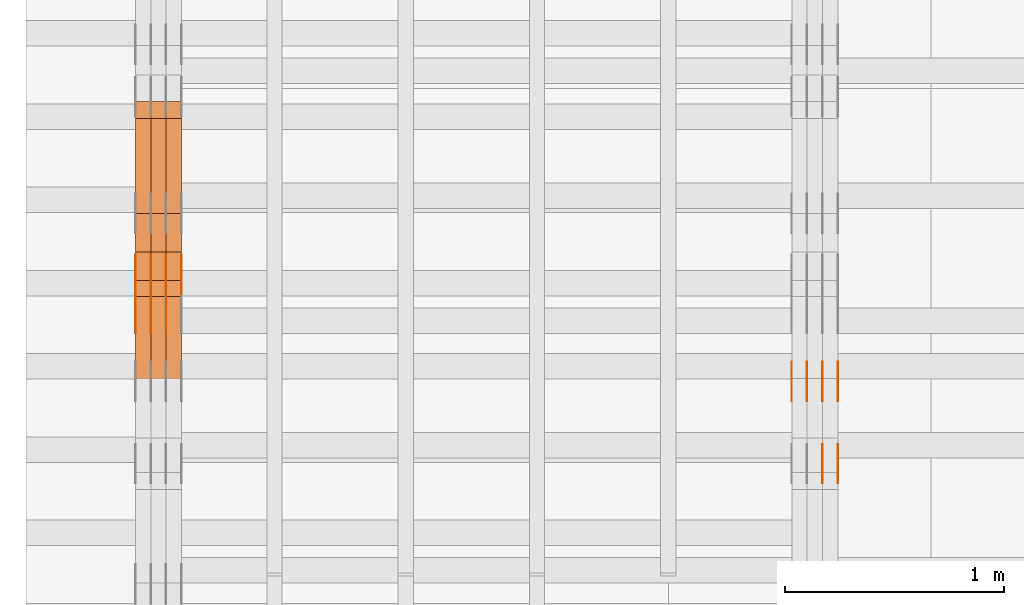
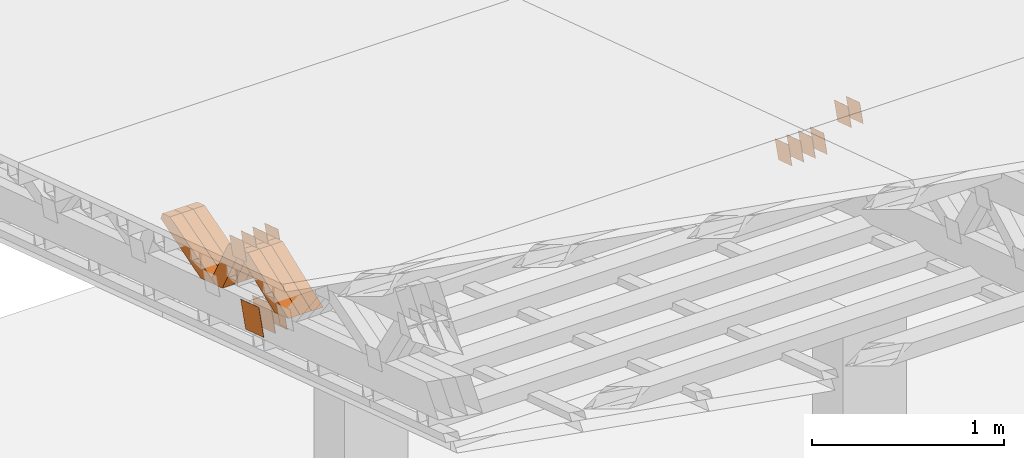
# One storey, part 175 of 385: 28 proxies.
"""IFC2X3 building model written with IfcOpenShell, lengths in millimetres."""

from ifc_helpers import new_model, entity, si_unit, converted_unit, derived_unit, direction, frame, origin, place, context, subcontext, project, spatial, polyline, outline, extrude, source, transform, mapped, material, type_object, type_shapes, element, save


model = new_model("IFC2X3")

# Units and contexts
model_context = context("Model", 3, precision=0.01, world=origin(), true_north=direction((6.12303176911189e-17, 1.0)))
body_context = subcontext(model_context, "Body", "Model", "MODEL_VIEW")
ifc_project = project(units=[si_unit("LENGTHUNIT", "METRE", prefix="MILLI"), si_unit("AREAUNIT", "SQUARE_METRE"), si_unit("VOLUMEUNIT", "CUBIC_METRE"), converted_unit("PLANEANGLEUNIT", "DEGREE", entity("IfcRatioMeasure", 0.0174532925199433), si_unit("PLANEANGLEUNIT", "RADIAN"), dimensions=[0, 0, 0, 0, 0, 0, 0]), si_unit("MASSUNIT", "GRAM", prefix="KILO"), derived_unit("MASSDENSITYUNIT", [(si_unit("MASSUNIT", "GRAM", prefix="KILO"), 1), (si_unit("LENGTHUNIT", "METRE"), -3)]), si_unit("TIMEUNIT", "SECOND"), si_unit("FREQUENCYUNIT", "HERTZ"), si_unit("THERMODYNAMICTEMPERATUREUNIT", "DEGREE_CELSIUS"), derived_unit("THERMALTRANSMITTANCEUNIT", [(si_unit("MASSUNIT", "GRAM", prefix="KILO"), 1), (si_unit("THERMODYNAMICTEMPERATUREUNIT", "KELVIN"), -1), (si_unit("TIMEUNIT", "SECOND"), -3)]), derived_unit("VOLUMETRICFLOWRATEUNIT", [(si_unit("LENGTHUNIT", "METRE"), 3), (si_unit("TIMEUNIT", "SECOND"), -1)]), si_unit("ELECTRICCURRENTUNIT", "AMPERE"), si_unit("ELECTRICVOLTAGEUNIT", "VOLT"), si_unit("POWERUNIT", "WATT"), si_unit("FORCEUNIT", "NEWTON", prefix="KILO"), si_unit("ILLUMINANCEUNIT", "LUX"), si_unit("LUMINOUSFLUXUNIT", "LUMEN"), si_unit("LUMINOUSINTENSITYUNIT", "CANDELA"), derived_unit("USERDEFINED", [(si_unit("MASSUNIT", "GRAM", prefix="KILO"), -1), (si_unit("LENGTHUNIT", "METRE"), -2), (si_unit("TIMEUNIT", "SECOND"), 3), (si_unit("LUMINOUSFLUXUNIT", "LUMEN"), 1)]), derived_unit("LINEARVELOCITYUNIT", [(si_unit("LENGTHUNIT", "METRE"), 1), (si_unit("TIMEUNIT", "SECOND"), -1)]), si_unit("PRESSUREUNIT", "PASCAL"), derived_unit("USERDEFINED", [(si_unit("LENGTHUNIT", "METRE"), -2), (si_unit("MASSUNIT", "GRAM", prefix="KILO"), 1), (si_unit("TIMEUNIT", "SECOND"), -2)])], contexts=[model_context])

# Site, building, storey
site_placement = place(None, origin())
site = spatial("IfcSite", under=ifc_project, at=site_placement, CompositionType="ELEMENT")
building_placement = place(site_placement, origin())
building = spatial("IfcBuilding", under=site, at=building_placement, CompositionType="ELEMENT")
storey_placement = place(building_placement, origin())
storey = spatial("IfcBuildingStorey", under=building, at=storey_placement, Name="Default", CompositionType="ELEMENT", Elevation=0.0)

# Proxies
ifc_material_1 = material(Name="IfcSurfaceStyle #65598")
building_element_proxy_type_1 = type_object("IfcBuildingElementProxyType", PredefinedType="NOTDEFINED", material=ifc_material_1)
shared_shape_1 = source(origin(), body_context, "Body", "SweptSolid", [
    extrude(outline(polyline([(-75.0001116115454, -60.0000599592451), (75.0000887592496, -60.0000599592451), (75.0001116115454, 60.0000599592451), (-75.0000887592496, 60.0000599592451), (-75.0001116115454, -60.0000599592451)])), frame((75.0001116115454, 60.0000599592451, 0.0), z_axis=(0.0, 0.0, 1.0), x_axis=(-1.0, 0.0, 0.0)), (0.0, 0.0, 1.0), 1.3),
])
type_shapes(building_element_proxy_type_1, [shared_shape_1])
proxy_1_placement = place(building_placement, frame((3386.29999999999, 21881.0815195707, 1532.2522473242), z_axis=(-1.0, 0.0, 0.0), x_axis=(0.0, -0.951056516295124, 0.309016994375039)))
element("IfcBuildingElementProxy", 1, at=proxy_1_placement, inside=storey, type_object=building_element_proxy_type_1, material=ifc_material_1, context=body_context, shape_type="MappedRepresentation", body=[
    mapped(shared_shape_1, transform((0.0, 0.0, 0.0), scale=1.0)),
])
ifc_material_2 = material(Name="IfcSurfaceStyle #65541")
building_element_proxy_type_2 = type_object("IfcBuildingElementProxyType", PredefinedType="NOTDEFINED", material=ifc_material_2)
shared_shape_2 = source(origin(), body_context, "Body", "SweptSolid", [
    extrude(outline(polyline([(-75.0001116115454, -60.0000599592451), (75.0000887592496, -60.0000599592451), (75.0001116115454, 60.0000599592451), (-75.0000887592496, 60.0000599592451), (-75.0001116115454, -60.0000599592451)])), frame((75.0001116115454, 60.0000599592451, 0.0), z_axis=(0.0, 0.0, 1.0), x_axis=(-1.0, 0.0, 0.0)), (0.0, 0.0, 1.0), 1.3),
])
type_shapes(building_element_proxy_type_2, [shared_shape_2])
proxy_2_placement = place(building_placement, frame((3315.0, 21881.0815195707, 1532.2522473242), z_axis=(-1.0, 0.0, 0.0), x_axis=(0.0, -0.951056516295124, 0.309016994375039)))
element("IfcBuildingElementProxy", 2, at=proxy_2_placement, inside=storey, type_object=building_element_proxy_type_2, material=ifc_material_2, context=body_context, shape_type="MappedRepresentation", body=[
    mapped(shared_shape_2, transform((0.0, 0.0, 0.0), scale=1.0)),
])
ifc_material_3 = material(Name="IfcSurfaceStyle #65484")
building_element_proxy_type_3 = type_object("IfcBuildingElementProxyType", PredefinedType="NOTDEFINED", material=ifc_material_3)
shared_shape_3 = source(origin(), body_context, "Body", "SweptSolid", [
    extrude(outline(polyline([(-75.0001116115454, -60.0000599592451), (75.0000887592496, -60.0000599592451), (75.0001116115454, 60.0000599592451), (-75.0000887592496, 60.0000599592451), (-75.0001116115454, -60.0000599592451)])), frame((75.0001116115454, 60.0000599592451, 0.0), z_axis=(0.0, 0.0, 1.0), x_axis=(-1.0, 0.0, 0.0)), (0.0, 0.0, 1.0), 1.3),
])
type_shapes(building_element_proxy_type_3, [shared_shape_3])
proxy_3_placement = place(building_placement, frame((3316.29999999999, 21881.0815195707, 1532.2522473242), z_axis=(-1.0, 0.0, 0.0), x_axis=(0.0, -0.951056516295124, 0.309016994375039)))
element("IfcBuildingElementProxy", 3, at=proxy_3_placement, inside=storey, type_object=building_element_proxy_type_3, material=ifc_material_3, context=body_context, shape_type="MappedRepresentation", body=[
    mapped(shared_shape_3, transform((0.0, 0.0, 0.0), scale=1.0)),
])
ifc_material_4 = material(Name="IfcSurfaceStyle #65427")
building_element_proxy_type_4 = type_object("IfcBuildingElementProxyType", PredefinedType="NOTDEFINED", material=ifc_material_4)
shared_shape_4 = source(origin(), body_context, "Body", "SweptSolid", [
    extrude(outline(polyline([(-75.0001116115454, -60.0000599592451), (75.0000887592496, -60.0000599592451), (75.0001116115454, 60.0000599592451), (-75.0000887592496, 60.0000599592451), (-75.0001116115454, -60.0000599592451)])), frame((75.0001116115454, 60.0000599592451, 0.0), z_axis=(0.0, 0.0, 1.0), x_axis=(-1.0, 0.0, 0.0)), (0.0, 0.0, 1.0), 1.29999999999999),
])
type_shapes(building_element_proxy_type_4, [shared_shape_4])
proxy_4_placement = place(building_placement, frame((3245.0, 21881.0815195707, 1532.2522473242), z_axis=(-1.0, 0.0, 0.0), x_axis=(0.0, -0.951056516295124, 0.309016994375039)))
element("IfcBuildingElementProxy", 4, at=proxy_4_placement, inside=storey, type_object=building_element_proxy_type_4, material=ifc_material_4, context=body_context, shape_type="MappedRepresentation", body=[
    mapped(shared_shape_4, transform((0.0, 0.0, 0.0), scale=1.0)),
])
ifc_material_5 = material(Name="IfcSurfaceStyle #65370")
building_element_proxy_type_5 = type_object("IfcBuildingElementProxyType", PredefinedType="NOTDEFINED", material=ifc_material_5)
shared_shape_5 = source(origin(), body_context, "Body", "SweptSolid", [
    extrude(outline(polyline([(-75.0001116115454, -60.0000599592451), (75.0000887592496, -60.0000599592451), (75.0001116115454, 60.0000599592451), (-75.0000887592496, 60.0000599592451), (-75.0001116115454, -60.0000599592451)])), frame((75.0001116115454, 60.0000599592451, 0.0), z_axis=(0.0, 0.0, 1.0), x_axis=(-1.0, 0.0, 0.0)), (0.0, 0.0, 1.0), 1.29999999999999),
])
type_shapes(building_element_proxy_type_5, [shared_shape_5])
proxy_5_placement = place(building_placement, frame((3246.29999999999, 21881.0815195707, 1532.2522473242), z_axis=(-1.0, 0.0, 0.0), x_axis=(0.0, -0.951056516295124, 0.309016994375039)))
element("IfcBuildingElementProxy", 5, at=proxy_5_placement, inside=storey, type_object=building_element_proxy_type_5, material=ifc_material_5, context=body_context, shape_type="MappedRepresentation", body=[
    mapped(shared_shape_5, transform((0.0, 0.0, 0.0), scale=1.0)),
])
ifc_material_6 = material(Name="IfcSurfaceStyle #65313")
building_element_proxy_type_6 = type_object("IfcBuildingElementProxyType", PredefinedType="NOTDEFINED", material=ifc_material_6)
shared_shape_6 = source(origin(), body_context, "Body", "SweptSolid", [
    extrude(outline(polyline([(-75.0001116115454, -60.0000599592451), (75.0000887592496, -60.0000599592451), (75.0001116115454, 60.0000599592451), (-75.0000887592496, 60.0000599592451), (-75.0001116115454, -60.0000599592451)])), frame((75.0001116115454, 60.0000599592451, 0.0), z_axis=(0.0, 0.0, 1.0), x_axis=(-1.0, 0.0, 0.0)), (0.0, 0.0, 1.0), 1.29999999999999),
])
type_shapes(building_element_proxy_type_6, [shared_shape_6])
proxy_6_placement = place(building_placement, frame((3175.0, 21881.0815195707, 1532.2522473242), z_axis=(-1.0, 0.0, 0.0), x_axis=(0.0, -0.951056516295124, 0.309016994375039)))
element("IfcBuildingElementProxy", 6, at=proxy_6_placement, inside=storey, type_object=building_element_proxy_type_6, material=ifc_material_6, context=body_context, shape_type="MappedRepresentation", body=[
    mapped(shared_shape_6, transform((0.0, 0.0, 0.0), scale=1.0)),
])
ifc_material_7 = material(Name="IfcSurfaceStyle #60126")
building_element_proxy_type_7 = type_object("IfcBuildingElementProxyType", PredefinedType="NOTDEFINED", material=ifc_material_7)
shared_shape_7 = source(origin(), body_context, "Body", "SweptSolid", [
    extrude(outline(polyline([(-74.9998794200064, -59.9999845156358), (74.9998565677224, -59.9999845156358), (74.9998794200064, 59.9999845156358), (-74.9998565677224, 59.9999845156358), (-74.9998794200064, -59.9999845156358)])), frame((74.9999765995044, 60.0000596852337, 0.0), z_axis=(0.0, 0.0, 1.0), x_axis=(-1.0, 0.0, 0.0)), (0.0, 0.0, 1.0), 1.3),
])
type_shapes(building_element_proxy_type_7, [shared_shape_7])
proxy_7_placement = place(building_placement, frame((3386.29999999999, 21505.9776314857, 1954.5332951652), z_axis=(-1.0, 0.0, 0.0), x_axis=(0.0, -0.951056516295154, 0.309016994374948)))
element("IfcBuildingElementProxy", 7, at=proxy_7_placement, inside=storey, type_object=building_element_proxy_type_7, material=ifc_material_7, context=body_context, shape_type="MappedRepresentation", body=[
    mapped(shared_shape_7, transform((0.0, 0.0, 0.0), scale=1.0)),
])
ifc_material_8 = material(Name="IfcSurfaceStyle #60069")
building_element_proxy_type_8 = type_object("IfcBuildingElementProxyType", PredefinedType="NOTDEFINED", material=ifc_material_8)
shared_shape_8 = source(origin(), body_context, "Body", "SweptSolid", [
    extrude(outline(polyline([(-74.9998794200064, -59.9999845156358), (74.9998565677224, -59.9999845156358), (74.9998794200064, 59.9999845156358), (-74.9998565677224, 59.9999845156358), (-74.9998794200064, -59.9999845156358)])), frame((74.9999765995044, 60.0000596852337, 0.0), z_axis=(0.0, 0.0, 1.0), x_axis=(-1.0, 0.0, 0.0)), (0.0, 0.0, 1.0), 1.3),
])
type_shapes(building_element_proxy_type_8, [shared_shape_8])
proxy_8_placement = place(building_placement, frame((3315.0, 21505.9776314857, 1954.5332951652), z_axis=(-1.0, 0.0, 0.0), x_axis=(0.0, -0.951056516295154, 0.309016994374948)))
element("IfcBuildingElementProxy", 8, at=proxy_8_placement, inside=storey, type_object=building_element_proxy_type_8, material=ifc_material_8, context=body_context, shape_type="MappedRepresentation", body=[
    mapped(shared_shape_8, transform((0.0, 0.0, 0.0), scale=1.0)),
])
ifc_material_9 = material(Name="IfcSurfaceStyle #60012")
building_element_proxy_type_9 = type_object("IfcBuildingElementProxyType", PredefinedType="NOTDEFINED", material=ifc_material_9)
shared_shape_9 = source(origin(), body_context, "Body", "SweptSolid", [
    extrude(outline(polyline([(-74.9998794200064, -59.9999845156358), (74.9998565677224, -59.9999845156358), (74.9998794200064, 59.9999845156358), (-74.9998565677224, 59.9999845156358), (-74.9998794200064, -59.9999845156358)])), frame((74.9999765995044, 60.0000596852337, 0.0), z_axis=(0.0, 0.0, 1.0), x_axis=(-1.0, 0.0, 0.0)), (0.0, 0.0, 1.0), 1.3),
])
type_shapes(building_element_proxy_type_9, [shared_shape_9])
proxy_9_placement = place(building_placement, frame((3316.29999999999, 21505.9776314857, 1954.5332951652), z_axis=(-1.0, 0.0, 0.0), x_axis=(0.0, -0.951056516295154, 0.309016994374948)))
element("IfcBuildingElementProxy", 9, at=proxy_9_placement, inside=storey, type_object=building_element_proxy_type_9, material=ifc_material_9, context=body_context, shape_type="MappedRepresentation", body=[
    mapped(shared_shape_9, transform((0.0, 0.0, 0.0), scale=1.0)),
])
ifc_material_10 = material(Name="IfcSurfaceStyle #33446")
building_element_proxy_type_10 = type_object("IfcBuildingElementProxyType", PredefinedType="NOTDEFINED", material=ifc_material_10)
shared_shape_10 = source(origin(), body_context, "Body", "SweptSolid", [
    extrude(outline(polyline([(-99.9999579276585, -84.0000593595837), (100.000141865112, -84.0000593595837), (99.9999579276589, 84.0000593595837), (-100.000141865112, 84.0000593595837), (-99.9999579276585, -84.0000593595837)])), frame((100.000141865112, 84.0000593595837, 0.0), z_axis=(0.0, 0.0, 1.0), x_axis=(-1.0, 0.0, 0.0)), (0.0, 0.0, 1.0), 1.3),
])
type_shapes(building_element_proxy_type_10, [shared_shape_10])
proxy_10_placement = place(building_placement, frame((316.299999999986, 22239.7296395088, 1287.96775368191), z_axis=(-1.0, 0.0, 0.0), x_axis=(0.0, -0.951056516295124, 0.309016994375039)))
element("IfcBuildingElementProxy", 10, at=proxy_10_placement, inside=storey, type_object=building_element_proxy_type_10, material=ifc_material_10, context=body_context, shape_type="MappedRepresentation", body=[
    mapped(shared_shape_10, transform((0.0, 0.0, 0.0), scale=1.0)),
])
ifc_material_11 = material(Name="IfcSurfaceStyle #33389")
building_element_proxy_type_11 = type_object("IfcBuildingElementProxyType", PredefinedType="NOTDEFINED", material=ifc_material_11)
shared_shape_11 = source(origin(), body_context, "Body", "SweptSolid", [
    extrude(outline(polyline([(-99.9999579276585, -84.0000593595837), (100.000141865112, -84.0000593595837), (99.9999579276589, 84.0000593595837), (-100.000141865112, 84.0000593595837), (-99.9999579276585, -84.0000593595837)])), frame((100.000141865112, 84.0000593595837, 0.0), z_axis=(0.0, 0.0, 1.0), x_axis=(-1.0, 0.0, 0.0)), (0.0, 0.0, 1.0), 1.29999999999998),
])
type_shapes(building_element_proxy_type_11, [shared_shape_11])
proxy_11_placement = place(building_placement, frame((245.0, 22239.7296395088, 1287.96775368191), z_axis=(-1.0, 0.0, 0.0), x_axis=(0.0, -0.951056516295124, 0.309016994375039)))
element("IfcBuildingElementProxy", 11, at=proxy_11_placement, inside=storey, type_object=building_element_proxy_type_11, material=ifc_material_11, context=body_context, shape_type="MappedRepresentation", body=[
    mapped(shared_shape_11, transform((0.0, 0.0, 0.0), scale=1.0)),
])
ifc_material_12 = material(Name="IfcSurfaceStyle #33332")
building_element_proxy_type_12 = type_object("IfcBuildingElementProxyType", PredefinedType="NOTDEFINED", material=ifc_material_12)
shared_shape_12 = source(origin(), body_context, "Body", "SweptSolid", [
    extrude(outline(polyline([(-99.9999579276585, -84.0000593595837), (100.000141865112, -84.0000593595837), (99.9999579276589, 84.0000593595837), (-100.000141865112, 84.0000593595837), (-99.9999579276585, -84.0000593595837)])), frame((100.000141865112, 84.0000593595837, 0.0), z_axis=(0.0, 0.0, 1.0), x_axis=(-1.0, 0.0, 0.0)), (0.0, 0.0, 1.0), 1.29999999999998),
])
type_shapes(building_element_proxy_type_12, [shared_shape_12])
proxy_12_placement = place(building_placement, frame((246.299999999986, 22239.7296395088, 1287.96775368191), z_axis=(-1.0, 0.0, 0.0), x_axis=(0.0, -0.951056516295124, 0.309016994375039)))
element("IfcBuildingElementProxy", 12, at=proxy_12_placement, inside=storey, type_object=building_element_proxy_type_12, material=ifc_material_12, context=body_context, shape_type="MappedRepresentation", body=[
    mapped(shared_shape_12, transform((0.0, 0.0, 0.0), scale=1.0)),
])
ifc_material_13 = material(Name="IfcSurfaceStyle #33275")
building_element_proxy_type_13 = type_object("IfcBuildingElementProxyType", PredefinedType="NOTDEFINED", material=ifc_material_13)
shared_shape_13 = source(origin(), body_context, "Body", "SweptSolid", [
    extrude(outline(polyline([(-99.9999579276585, -84.0000593595837), (100.000141865112, -84.0000593595837), (99.9999579276589, 84.0000593595837), (-100.000141865112, 84.0000593595837), (-99.9999579276585, -84.0000593595837)])), frame((100.000141865112, 84.0000593595837, 0.0), z_axis=(0.0, 0.0, 1.0), x_axis=(-1.0, 0.0, 0.0)), (0.0, 0.0, 1.0), 1.29999999999999),
])
type_shapes(building_element_proxy_type_13, [shared_shape_13])
proxy_13_placement = place(building_placement, frame((175.0, 22239.7296395088, 1287.96775368191), z_axis=(-1.0, 0.0, 0.0), x_axis=(0.0, -0.951056516295124, 0.309016994375039)))
element("IfcBuildingElementProxy", 13, at=proxy_13_placement, inside=storey, type_object=building_element_proxy_type_13, material=ifc_material_13, context=body_context, shape_type="MappedRepresentation", body=[
    mapped(shared_shape_13, transform((0.0, 0.0, 0.0), scale=1.0)),
])
ifc_material_14 = material(Name="IfcSurfaceStyle #25010")
building_element_proxy_type_14 = type_object("IfcBuildingElementProxyType", PredefinedType="NOTDEFINED", material=ifc_material_14)
shared_shape_14 = source(origin(), body_context, "Body", "SweptSolid", [
    extrude(outline(polyline([(-74.9998794200069, -59.9999845156358), (74.9998565677229, -59.9999845156358), (74.9998794200069, 59.9999845156358), (-74.9998565677229, 59.9999845156358), (-74.9998794200069, -59.9999845156358)])), frame((75.0000966453795, 60.0000596852335, 0.0), z_axis=(0.0, 0.0, 1.0), x_axis=(-1.0, 0.0, 0.0)), (0.0, 0.0, 1.0), 1.3),
])
type_shapes(building_element_proxy_type_14, [shared_shape_14])
proxy_14_placement = place(building_placement, frame((386.299999999986, 22372.1881948749, 1673.08440552992), z_axis=(-1.0, 0.0, 0.0), x_axis=(0.0, -0.951056516295154, 0.309016994374948)))
element("IfcBuildingElementProxy", 14, at=proxy_14_placement, inside=storey, type_object=building_element_proxy_type_14, material=ifc_material_14, context=body_context, shape_type="MappedRepresentation", body=[
    mapped(shared_shape_14, transform((0.0, 0.0, 0.0), scale=1.0)),
])
ifc_material_15 = material(Name="IfcSurfaceStyle #24953")
building_element_proxy_type_15 = type_object("IfcBuildingElementProxyType", PredefinedType="NOTDEFINED", material=ifc_material_15)
shared_shape_15 = source(origin(), body_context, "Body", "SweptSolid", [
    extrude(outline(polyline([(-74.9998794200069, -59.9999845156358), (74.9998565677229, -59.9999845156358), (74.9998794200069, 59.9999845156358), (-74.9998565677229, 59.9999845156358), (-74.9998794200069, -59.9999845156358)])), frame((75.0000966453795, 60.0000596852335, 0.0), z_axis=(0.0, 0.0, 1.0), x_axis=(-1.0, 0.0, 0.0)), (0.0, 0.0, 1.0), 1.3),
])
type_shapes(building_element_proxy_type_15, [shared_shape_15])
proxy_15_placement = place(building_placement, frame((315.0, 22372.1881948749, 1673.08440552992), z_axis=(-1.0, 0.0, 0.0), x_axis=(0.0, -0.951056516295154, 0.309016994374948)))
element("IfcBuildingElementProxy", 15, at=proxy_15_placement, inside=storey, type_object=building_element_proxy_type_15, material=ifc_material_15, context=body_context, shape_type="MappedRepresentation", body=[
    mapped(shared_shape_15, transform((0.0, 0.0, 0.0), scale=1.0)),
])
ifc_material_16 = material(Name="IfcSurfaceStyle #24896")
building_element_proxy_type_16 = type_object("IfcBuildingElementProxyType", PredefinedType="NOTDEFINED", material=ifc_material_16)
shared_shape_16 = source(origin(), body_context, "Body", "SweptSolid", [
    extrude(outline(polyline([(-74.9998794200069, -59.9999845156358), (74.9998565677229, -59.9999845156358), (74.9998794200069, 59.9999845156358), (-74.9998565677229, 59.9999845156358), (-74.9998794200069, -59.9999845156358)])), frame((75.0000966453795, 60.0000596852335, 0.0), z_axis=(0.0, 0.0, 1.0), x_axis=(-1.0, 0.0, 0.0)), (0.0, 0.0, 1.0), 1.3),
])
type_shapes(building_element_proxy_type_16, [shared_shape_16])
proxy_16_placement = place(building_placement, frame((316.299999999986, 22372.1881948749, 1673.08440552992), z_axis=(-1.0, 0.0, 0.0), x_axis=(0.0, -0.951056516295154, 0.309016994374948)))
element("IfcBuildingElementProxy", 16, at=proxy_16_placement, inside=storey, type_object=building_element_proxy_type_16, material=ifc_material_16, context=body_context, shape_type="MappedRepresentation", body=[
    mapped(shared_shape_16, transform((0.0, 0.0, 0.0), scale=1.0)),
])
ifc_material_17 = material(Name="IfcSurfaceStyle #24839")
building_element_proxy_type_17 = type_object("IfcBuildingElementProxyType", PredefinedType="NOTDEFINED", material=ifc_material_17)
shared_shape_17 = source(origin(), body_context, "Body", "SweptSolid", [
    extrude(outline(polyline([(-74.9998794200069, -59.9999845156358), (74.9998565677229, -59.9999845156358), (74.9998794200069, 59.9999845156358), (-74.9998565677229, 59.9999845156358), (-74.9998794200069, -59.9999845156358)])), frame((75.0000966453795, 60.0000596852335, 0.0), z_axis=(0.0, 0.0, 1.0), x_axis=(-1.0, 0.0, 0.0)), (0.0, 0.0, 1.0), 1.29999999999999),
])
type_shapes(building_element_proxy_type_17, [shared_shape_17])
proxy_17_placement = place(building_placement, frame((245.0, 22372.1881948749, 1673.08440552992), z_axis=(-1.0, 0.0, 0.0), x_axis=(0.0, -0.951056516295154, 0.309016994374948)))
element("IfcBuildingElementProxy", 17, at=proxy_17_placement, inside=storey, type_object=building_element_proxy_type_17, material=ifc_material_17, context=body_context, shape_type="MappedRepresentation", body=[
    mapped(shared_shape_17, transform((0.0, 0.0, 0.0), scale=1.0)),
])
ifc_material_18 = material(Name="IfcSurfaceStyle #24782")
building_element_proxy_type_18 = type_object("IfcBuildingElementProxyType", PredefinedType="NOTDEFINED", material=ifc_material_18)
shared_shape_18 = source(origin(), body_context, "Body", "SweptSolid", [
    extrude(outline(polyline([(-74.9998794200069, -59.9999845156358), (74.9998565677229, -59.9999845156358), (74.9998794200069, 59.9999845156358), (-74.9998565677229, 59.9999845156358), (-74.9998794200069, -59.9999845156358)])), frame((75.0000966453795, 60.0000596852335, 0.0), z_axis=(0.0, 0.0, 1.0), x_axis=(-1.0, 0.0, 0.0)), (0.0, 0.0, 1.0), 1.29999999999999),
])
type_shapes(building_element_proxy_type_18, [shared_shape_18])
proxy_18_placement = place(building_placement, frame((246.299999999986, 22372.1881948749, 1673.08440552992), z_axis=(-1.0, 0.0, 0.0), x_axis=(0.0, -0.951056516295154, 0.309016994374948)))
element("IfcBuildingElementProxy", 18, at=proxy_18_placement, inside=storey, type_object=building_element_proxy_type_18, material=ifc_material_18, context=body_context, shape_type="MappedRepresentation", body=[
    mapped(shared_shape_18, transform((0.0, 0.0, 0.0), scale=1.0)),
])
ifc_material_19 = material(Name="IfcSurfaceStyle #24725")
building_element_proxy_type_19 = type_object("IfcBuildingElementProxyType", PredefinedType="NOTDEFINED", material=ifc_material_19)
shared_shape_19 = source(origin(), body_context, "Body", "SweptSolid", [
    extrude(outline(polyline([(-74.9998794200069, -59.9999845156358), (74.9998565677229, -59.9999845156358), (74.9998794200069, 59.9999845156358), (-74.9998565677229, 59.9999845156358), (-74.9998794200069, -59.9999845156358)])), frame((75.0000966453795, 60.0000596852335, 0.0), z_axis=(0.0, 0.0, 1.0), x_axis=(-1.0, 0.0, 0.0)), (0.0, 0.0, 1.0), 1.29999999999999),
])
type_shapes(building_element_proxy_type_19, [shared_shape_19])
proxy_19_placement = place(building_placement, frame((175.0, 22372.1881948749, 1673.08440552992), z_axis=(-1.0, 0.0, 0.0), x_axis=(0.0, -0.951056516295154, 0.309016994374948)))
element("IfcBuildingElementProxy", 19, at=proxy_19_placement, inside=storey, type_object=building_element_proxy_type_19, material=ifc_material_19, context=body_context, shape_type="MappedRepresentation", body=[
    mapped(shared_shape_19, transform((0.0, 0.0, 0.0), scale=1.0)),
])
ifc_material_20 = material(Name="IfcSurfaceStyle #12662")
building_element_proxy_type_20 = type_object("IfcBuildingElementProxyType", Name="T1-W30 12660", PredefinedType="NOTDEFINED", material=ifc_material_20)
shared_shape_20 = source(origin(), body_context, "Body", "SweptSolid", [
    extrude(outline(polyline([(-319.322304176575, -47.5000259045904), (133.154090927094, -47.5000259045904), (191.489196707701, 6.99403755251016e-06), (197.330697834052, 47.5000224075717), (-202.651681292271, 47.5000224075717), (-319.322304176575, -47.5000259045904)])), frame((197.330834478517, 47.5000608592405, 0.0), z_axis=(0.0, 0.0, 1.0), x_axis=(-1.0, 0.0, 0.0)), (0.0, 0.0, 1.0), 70.0),
])
type_shapes(building_element_proxy_type_20, [shared_shape_20])
proxy_20_placement = place(building_placement, frame((385.0, 22312.5352975627, 1720.70362673362), z_axis=(-1.0, 0.0, 0.0), x_axis=(0.0, -0.932610696879359, -0.360884036868072)))
element("IfcBuildingElementProxy", 20, at=proxy_20_placement, inside=storey, type_object=building_element_proxy_type_20, material=ifc_material_20, Name="T1-W30", context=body_context, shape_type="MappedRepresentation", body=[
    mapped(shared_shape_20, transform((0.0, 0.0, 0.0), scale=1.0)),
])
ifc_material_21 = material(Name="IfcSurfaceStyle #12596")
building_element_proxy_type_21 = type_object("IfcBuildingElementProxyType", Name="T1-W30 12594", PredefinedType="NOTDEFINED", material=ifc_material_21)
shared_shape_21 = source(origin(), body_context, "Body", "SweptSolid", [
    extrude(outline(polyline([(-319.322304176575, -47.5000259045904), (133.154090927094, -47.5000259045904), (191.489196707701, 6.99403755251016e-06), (197.330697834052, 47.5000224075717), (-202.651681292271, 47.5000224075717), (-319.322304176575, -47.5000259045904)])), frame((197.330834478517, 47.5000608592405, 0.0), z_axis=(0.0, 0.0, 1.0), x_axis=(-1.0, 0.0, 0.0)), (0.0, 0.0, 1.0), 70.0),
])
type_shapes(building_element_proxy_type_21, [shared_shape_21])
proxy_21_placement = place(building_placement, frame((315.0, 22312.5352975627, 1720.70362673362), z_axis=(-1.0, 0.0, 0.0), x_axis=(0.0, -0.932610696879359, -0.360884036868072)))
element("IfcBuildingElementProxy", 21, at=proxy_21_placement, inside=storey, type_object=building_element_proxy_type_21, material=ifc_material_21, Name="T1-W30", context=body_context, shape_type="MappedRepresentation", body=[
    mapped(shared_shape_21, transform((0.0, 0.0, 0.0), scale=1.0)),
])
ifc_material_22 = material(Name="IfcSurfaceStyle #12530")
building_element_proxy_type_22 = type_object("IfcBuildingElementProxyType", Name="T1-W30 12528", PredefinedType="NOTDEFINED", material=ifc_material_22)
shared_shape_22 = source(origin(), body_context, "Body", "SweptSolid", [
    extrude(outline(polyline([(-319.322304176575, -47.5000259045904), (133.154090927094, -47.5000259045904), (191.489196707701, 6.99403755251016e-06), (197.330697834052, 47.5000224075717), (-202.651681292271, 47.5000224075717), (-319.322304176575, -47.5000259045904)])), frame((197.330834478517, 47.5000608592405, 0.0), z_axis=(0.0, 0.0, 1.0), x_axis=(-1.0, 0.0, 0.0)), (0.0, 0.0, 1.0), 70.0),
])
type_shapes(building_element_proxy_type_22, [shared_shape_22])
proxy_22_placement = place(building_placement, frame((245.0, 22312.5352975627, 1720.70362673362), z_axis=(-1.0, 0.0, 0.0), x_axis=(0.0, -0.932610696879359, -0.360884036868072)))
element("IfcBuildingElementProxy", 22, at=proxy_22_placement, inside=storey, type_object=building_element_proxy_type_22, material=ifc_material_22, Name="T1-W30", context=body_context, shape_type="MappedRepresentation", body=[
    mapped(shared_shape_22, transform((0.0, 0.0, 0.0), scale=1.0)),
])
ifc_material_23 = material(Name="IfcSurfaceStyle #12266")
building_element_proxy_type_23 = type_object("IfcBuildingElementProxyType", Name="T1-W41 12264", PredefinedType="NOTDEFINED", material=ifc_material_23)
shared_shape_23 = source(origin(), body_context, "Body", "SweptSolid", [
    extrude(outline(polyline([(-190.064783497519, -47.5001011048749), (182.590736871656, -47.5001011048749), (172.978793750747, 0.000111395300689243), (123.505951450908, 47.5000454072246), (-289.010698575792, 47.5000454072246), (-190.064783497519, -47.5001011048749)])), frame((182.590736871656, 47.5001973817447, 0.0), z_axis=(0.0, 0.0, 1.0), x_axis=(-1.0, 0.0, 0.0)), (0.0, 0.0, 1.0), 70.0),
])
type_shapes(building_element_proxy_type_23, [shared_shape_23])
proxy_23_placement = place(building_placement, frame((385.0, 22512.5506969063, 1347.13648051689), z_axis=(-1.0, 0.0, 0.0), x_axis=(0.0, -0.472020158706979, 0.881587755004706)))
element("IfcBuildingElementProxy", 23, at=proxy_23_placement, inside=storey, type_object=building_element_proxy_type_23, material=ifc_material_23, Name="T1-W41", context=body_context, shape_type="MappedRepresentation", body=[
    mapped(shared_shape_23, transform((0.0, 0.0, 0.0), scale=1.0)),
])
ifc_material_24 = material(Name="IfcSurfaceStyle #12200")
building_element_proxy_type_24 = type_object("IfcBuildingElementProxyType", Name="T1-W41 12198", PredefinedType="NOTDEFINED", material=ifc_material_24)
shared_shape_24 = source(origin(), body_context, "Body", "SweptSolid", [
    extrude(outline(polyline([(-190.064783497519, -47.5001011048749), (182.590736871656, -47.5001011048749), (172.978793750747, 0.000111395300689243), (123.505951450908, 47.5000454072246), (-289.010698575792, 47.5000454072246), (-190.064783497519, -47.5001011048749)])), frame((182.590736871656, 47.5001973817447, 0.0), z_axis=(0.0, 0.0, 1.0), x_axis=(-1.0, 0.0, 0.0)), (0.0, 0.0, 1.0), 70.0),
])
type_shapes(building_element_proxy_type_24, [shared_shape_24])
proxy_24_placement = place(building_placement, frame((315.0, 22512.5506969063, 1347.13648051689), z_axis=(-1.0, 0.0, 0.0), x_axis=(0.0, -0.472020158706979, 0.881587755004706)))
element("IfcBuildingElementProxy", 24, at=proxy_24_placement, inside=storey, type_object=building_element_proxy_type_24, material=ifc_material_24, Name="T1-W41", context=body_context, shape_type="MappedRepresentation", body=[
    mapped(shared_shape_24, transform((0.0, 0.0, 0.0), scale=1.0)),
])
ifc_material_25 = material(Name="IfcSurfaceStyle #12134")
building_element_proxy_type_25 = type_object("IfcBuildingElementProxyType", Name="T1-W41 12132", PredefinedType="NOTDEFINED", material=ifc_material_25)
shared_shape_25 = source(origin(), body_context, "Body", "SweptSolid", [
    extrude(outline(polyline([(-190.064783497519, -47.5001011048749), (182.590736871656, -47.5001011048749), (172.978793750747, 0.000111395300689243), (123.505951450908, 47.5000454072246), (-289.010698575792, 47.5000454072246), (-190.064783497519, -47.5001011048749)])), frame((182.590736871656, 47.5001973817447, 0.0), z_axis=(0.0, 0.0, 1.0), x_axis=(-1.0, 0.0, 0.0)), (0.0, 0.0, 1.0), 70.0),
])
type_shapes(building_element_proxy_type_25, [shared_shape_25])
proxy_25_placement = place(building_placement, frame((245.0, 22512.5506969063, 1347.13648051689), z_axis=(-1.0, 0.0, 0.0), x_axis=(0.0, -0.472020158706979, 0.881587755004706)))
element("IfcBuildingElementProxy", 25, at=proxy_25_placement, inside=storey, type_object=building_element_proxy_type_25, material=ifc_material_25, Name="T1-W41", context=body_context, shape_type="MappedRepresentation", body=[
    mapped(shared_shape_25, transform((0.0, 0.0, 0.0), scale=1.0)),
])
ifc_material_26 = material(Name="IfcSurfaceStyle #11870")
building_element_proxy_type_26 = type_object("IfcBuildingElementProxyType", Name="T1-W23 11868", PredefinedType="NOTDEFINED", material=ifc_material_26)
shared_shape_26 = source(origin(), body_context, "Body", "SweptSolid", [
    extrude(outline(polyline([(-356.808656505462, -47.5000180192671), (144.726334557508, -47.5000180192671), (213.258834104997, -2.90494310381195e-05), (218.567145253444, 47.5000325439826), (-219.743657410487, 47.5000325439827), (-356.808656505462, -47.5000180192671)])), frame((218.567145253444, 47.5000325439826, 0.0), z_axis=(0.0, 0.0, 1.0), x_axis=(-1.0, 0.0, 0.0)), (0.0, 0.0, 1.0), 70.0),
])
type_shapes(building_element_proxy_type_26, [shared_shape_26])
proxy_26_placement = place(building_placement, frame((385.0, 23128.2626953125, 1452.63940429688), z_axis=(-1.0, 0.0, 0.0), x_axis=(0.0, -0.957692700226705, -0.287792793399143)))
element("IfcBuildingElementProxy", 26, at=proxy_26_placement, inside=storey, type_object=building_element_proxy_type_26, material=ifc_material_26, Name="T1-W23", context=body_context, shape_type="MappedRepresentation", body=[
    mapped(shared_shape_26, transform((0.0, 0.0, 0.0), scale=1.0)),
])
ifc_material_27 = material(Name="IfcSurfaceStyle #11804")
building_element_proxy_type_27 = type_object("IfcBuildingElementProxyType", Name="T1-W23 11802", PredefinedType="NOTDEFINED", material=ifc_material_27)
shared_shape_27 = source(origin(), body_context, "Body", "SweptSolid", [
    extrude(outline(polyline([(-356.808656505462, -47.5000180192671), (144.726334557508, -47.5000180192671), (213.258834104997, -2.90494310381195e-05), (218.567145253444, 47.5000325439826), (-219.743657410487, 47.5000325439827), (-356.808656505462, -47.5000180192671)])), frame((218.567145253444, 47.5000325439826, 0.0), z_axis=(0.0, 0.0, 1.0), x_axis=(-1.0, 0.0, 0.0)), (0.0, 0.0, 1.0), 70.0),
])
type_shapes(building_element_proxy_type_27, [shared_shape_27])
proxy_27_placement = place(building_placement, frame((315.0, 23128.2626953125, 1452.63940429688), z_axis=(-1.0, 0.0, 0.0), x_axis=(0.0, -0.957692700226705, -0.287792793399143)))
element("IfcBuildingElementProxy", 27, at=proxy_27_placement, inside=storey, type_object=building_element_proxy_type_27, material=ifc_material_27, Name="T1-W23", context=body_context, shape_type="MappedRepresentation", body=[
    mapped(shared_shape_27, transform((0.0, 0.0, 0.0), scale=1.0)),
])
ifc_material_28 = material(Name="IfcSurfaceStyle #11738")
building_element_proxy_type_28 = type_object("IfcBuildingElementProxyType", Name="T1-W23 11736", PredefinedType="NOTDEFINED", material=ifc_material_28)
shared_shape_28 = source(origin(), body_context, "Body", "SweptSolid", [
    extrude(outline(polyline([(-356.808656505462, -47.5000180192671), (144.726334557508, -47.5000180192671), (213.258834104997, -2.90494310381195e-05), (218.567145253444, 47.5000325439826), (-219.743657410487, 47.5000325439827), (-356.808656505462, -47.5000180192671)])), frame((218.567145253444, 47.5000325439826, 0.0), z_axis=(0.0, 0.0, 1.0), x_axis=(-1.0, 0.0, 0.0)), (0.0, 0.0, 1.0), 70.0),
])
type_shapes(building_element_proxy_type_28, [shared_shape_28])
proxy_28_placement = place(building_placement, frame((245.0, 23128.2626953125, 1452.63940429688), z_axis=(-1.0, 0.0, 0.0), x_axis=(0.0, -0.957692700226705, -0.287792793399143)))
element("IfcBuildingElementProxy", 28, at=proxy_28_placement, inside=storey, type_object=building_element_proxy_type_28, material=ifc_material_28, Name="T1-W23", context=body_context, shape_type="MappedRepresentation", body=[
    mapped(shared_shape_28, transform((0.0, 0.0, 0.0), scale=1.0)),
])

save(model, "model.ifc")
